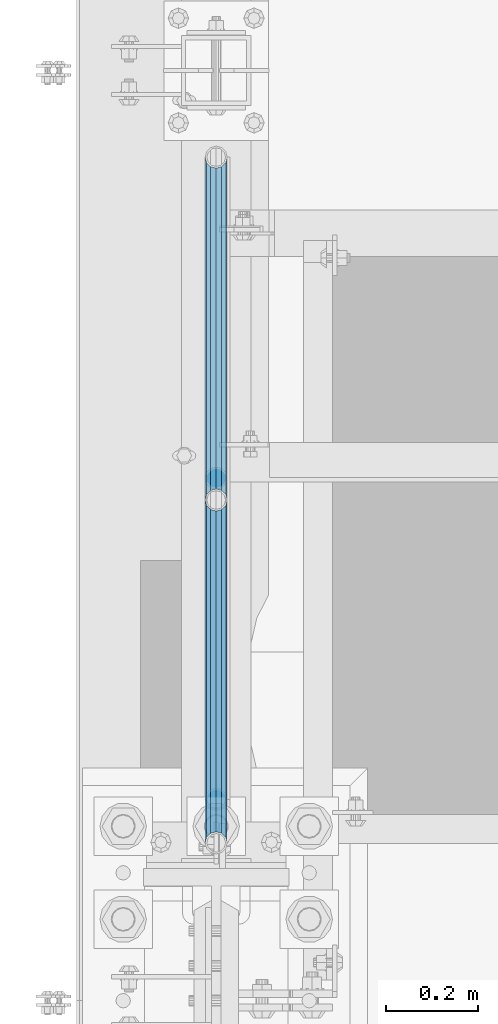
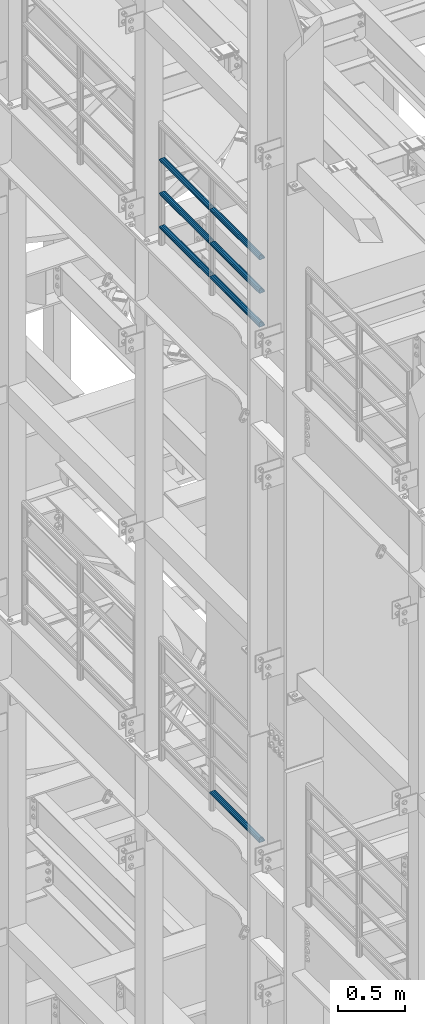
# One storey, part 1244 of 1876: 7 beams, 2 elements without a shape of their own.
"""IFC2X3 building model written with IfcOpenShell, lengths in millimetres."""

import ifcopenshell
import ifcopenshell.guid

model = None  # the IFC model being written
_history = None  # IfcOwnerHistory: only IFC2X3 demands one
_inside = {}  # id of a spatial element -> (the spatial element, [elements in it])
_under = {}  # id of a project, library or spatial element -> (it, [spatial elements below it])
_declared = {}  # id of a project -> (the project, [libraries it declares])
_typed = {}  # id of a type object -> (the type object, [elements of that type])
_made_of = {}  # id of a material, layer set ... -> (it, [elements and type objects made of it])


def new_model(schema):
    """Start an empty IFC model of exactly this schema.

    Asked for "IFC4X3", IfcOpenShell would pick the latest addendum, in which some entities
    have other attributes; the version numbers below select the first issue.
    IFC2X3 requires an IfcOwnerHistory on every rooted entity: one is made here for all.
    """
    global model, _history
    if schema == "IFC4X3":
        model = ifcopenshell.file(schema_version=(4, 3, 0, 0))
    else:
        model = ifcopenshell.file(schema=schema)
    _inside.clear()
    _under.clear()
    _declared.clear()
    _typed.clear()
    _made_of.clear()
    _history = None
    if model.schema == "IFC2X3":
        org = make("IfcOrganization", Name="unknown")
        user = make(
            "IfcPersonAndOrganization",
            ThePerson=make("IfcPerson", FamilyName="unknown"),
            TheOrganization=org,
        )
        app = make(
            "IfcApplication",
            ApplicationDeveloper=org,
            Version="unknown",
            ApplicationFullName="unknown",
            ApplicationIdentifier="unknown",
        )
        _history = make(
            "IfcOwnerHistory",
            OwningUser=user,
            OwningApplication=app,
            ChangeAction="ADDED",
            CreationDate=0,
        )
    return model


def make(cls, **values):
    """One entity of the class cls with the attributes given. An attribute that is None is left unset."""
    return model.create_entity(
        cls, **{name: value for name, value in values.items() if value is not None}
    )


def rooted(cls, **values):
    """An entity with a GlobalId (a new one), such as an element, a storey or a relation."""
    return make(cls, GlobalId=ifcopenshell.guid.new(), OwnerHistory=_history, **values)


def si_unit(unit_type, name, prefix=None):
    """IfcSIUnit, for example si_unit("LENGTHUNIT", "METRE", prefix="MILLI")."""
    return make("IfcSIUnit", UnitType=unit_type, Prefix=prefix, Name=name)


def assignment(units):
    """IfcUnitAssignment: the units of a project."""
    return None if units is None else make("IfcUnitAssignment", Units=units)


def point(xyz):
    """IfcCartesianPoint."""
    return None if xyz is None else make("IfcCartesianPoint", Coordinates=xyz)


def direction(xyz):
    """IfcDirection."""
    return None if xyz is None else make("IfcDirection", DirectionRatios=xyz)


def frame(location, z_axis=None, x_axis=None):
    """IfcAxis2Placement3D, a coordinate frame: its origin and axes. An axis left out is left unset."""
    return make(
        "IfcAxis2Placement3D",
        Location=point(location),
        Axis=direction(z_axis),
        RefDirection=direction(x_axis),
    )


def origin_with_axes():
    """The frame at (0, 0, 0) with the z axis (0, 0, 1) and the x axis (1, 0, 0) written out."""
    return frame((0.0, 0.0, 0.0), z_axis=(0.0, 0.0, 1.0), x_axis=(1.0, 0.0, 0.0))


def place(relative_to, where):
    """IfcLocalPlacement: puts the frame where relative to a parent placement (None: the world)."""
    return make(
        "IfcLocalPlacement", PlacementRelTo=relative_to, RelativePlacement=where
    )


def context(
    kind, dimensions, precision=None, world=None, true_north=None, identifier=None
):
    """IfcGeometricRepresentationContext, for example the 3D "Model" context."""
    return make(
        "IfcGeometricRepresentationContext",
        ContextIdentifier=identifier,
        ContextType=kind,
        CoordinateSpaceDimension=dimensions,
        Precision=precision,
        WorldCoordinateSystem=world,
        TrueNorth=true_north,
    )


def subcontext(parent, identifier, kind, view, scale=None):
    """IfcGeometricRepresentationSubContext, for example "Body" below "Model"."""
    return make(
        "IfcGeometricRepresentationSubContext",
        ContextIdentifier=identifier,
        ContextType=kind,
        ParentContext=parent,
        TargetScale=scale,
        TargetView=view,
    )


def project(units=None, contexts=None):
    """IfcProject with its units and contexts."""
    return rooted(
        "IfcProject",
        Name="project",
        RepresentationContexts=contexts,
        UnitsInContext=assignment(units),
    )


def spatial(cls, under=None, at=None, **own):
    """A site, building, storey or space (cls), placed at a placement, below another one or the project."""
    s = rooted(cls, ObjectPlacement=at, **own)
    if under is not None:
        _under.setdefault(under.id(), (under, []))[1].append(s)
    return s


def faces_of(points, faces, orient=None, outer=None):
    """IfcFace entities. A face is a list of loops; a loop is a list of indices into points, from 0.

    orient and outer hold one flag for each loop. By default every Orientation is true, the
    first loop of a face is its IfcFaceOuterBound and the others are IfcFaceBound.
    """
    made = []
    for i, loops in enumerate(faces):
        bounds = []
        for j, loop in enumerate(loops):
            is_outer = j == 0 if outer is None else outer[i][j]
            bounds.append(
                make(
                    "IfcFaceOuterBound" if is_outer else "IfcFaceBound",
                    Bound=make("IfcPolyLoop", Polygon=[points[k] for k in loop]),
                    Orientation=True if orient is None else orient[i][j],
                )
            )
        made.append(make("IfcFace", Bounds=bounds))
    return made


def faceted_brep(points, faces, orient=None, outer=None, voids=None):
    """IfcFacetedBrep: a solid bounded by flat faces; with voids (closed shells), ...WithVoids."""
    shared = [point(p) for p in points]
    hull = make("IfcClosedShell", CfsFaces=faces_of(shared, faces, orient, outer))
    if voids is None:
        return make("IfcFacetedBrep", Outer=hull)
    return make(
        "IfcFacetedBrepWithVoids",
        Outer=hull,
        Voids=[
            make(cls, CfsFaces=faces_of(shared, fs, o, b)) for cls, fs, o, b in voids
        ],
    )


def shape(context_of_items, identifier, shape_type, items):
    """IfcShapeRepresentation: the items that make up one representation, for example the "Body"."""
    return make(
        "IfcShapeRepresentation",
        ContextOfItems=context_of_items,
        RepresentationIdentifier=identifier,
        RepresentationType=shape_type,
        Items=items,
    )


def material(Name=None, Category=None):
    """IfcMaterial."""
    return make("IfcMaterial", Name=Name, Category=Category)


def made_of(thing, what):
    """Note that an element or type object is made of a material, layer set ...; save() writes the relation."""
    if what is not None:
        _made_of.setdefault(what.id(), (what, []))[1].append(thing)
    return thing


def type_object(cls, material=None, **own):
    """A type object (cls), such as IfcWallType, which elements share."""
    return made_of(rooted(cls, **own), material)


def element(
    cls,
    number,
    at=None,
    inside=None,
    cuts=None,
    type_object=None,
    material=None,
    context=None,
    identifier="Body",
    shape_type=None,
    held_by="IfcProductDefinitionShape",
    body=None,
    shapes=None,
    **own,
):
    """One element of the class cls, such as IfcWall. Its Tag is "e" and its number.

    at: its placement. inside: the storey or other place that contains it. cuts: it is an
    opening in that element (IfcRelVoidsElement). A single representation is given by context,
    identifier, shape_type and body (its items); several are given by shapes. held_by: the class
    of the entity that holds the representations. save() writes the other relations.
    """
    e = rooted(cls, Tag="e%d" % number, ObjectPlacement=at, **own)
    if body is not None:
        shapes = [shape(context, identifier, shape_type, body)]
    if shapes is not None:
        e.Representation = make(held_by, Representations=shapes)
    if inside is not None:
        _inside.setdefault(inside.id(), (inside, []))[1].append(e)
    if cuts is not None:
        rooted(
            "IfcRelVoidsElement", RelatingBuildingElement=cuts, RelatedOpeningElement=e
        )
    if type_object is not None:
        _typed.setdefault(type_object.id(), (type_object, []))[1].append(e)
    return made_of(e, material)


def aggregate(whole, parts):
    """IfcRelAggregates: a whole, such as a stair, and the parts it consists of."""
    return rooted("IfcRelAggregates", RelatingObject=whole, RelatedObjects=parts)


def save(model, path):
    """Write the relations noted so far, then the file.

    IfcRelAggregates (storeys below a building ...), IfcRelContainedInSpatialStructure (elements
    in a storey), IfcRelDefinesByType, IfcRelAssociatesMaterial and IfcRelDeclares: one each for
    every whole, place, type object, material and project.
    """
    for whole, parts in _under.values():
        aggregate(whole, parts)
    for where, things in _inside.values():
        rooted(
            "IfcRelContainedInSpatialStructure",
            RelatedElements=things,
            RelatingStructure=where,
        )
    for kind, things in _typed.values():
        rooted("IfcRelDefinesByType", RelatedObjects=things, RelatingType=kind)
    for what, things in _made_of.values():
        rooted("IfcRelAssociatesMaterial", RelatedObjects=things, RelatingMaterial=what)
    for by, libraries in _declared.values():
        rooted("IfcRelDeclares", RelatingContext=by, RelatedDefinitions=libraries)
    model.write(path)


model = new_model("IFC2X3")

# Units and contexts
model_context = context("Model", 3, precision=1e-05, world=origin_with_axes())
body_context = subcontext(model_context, "Body", "Model", "MODEL_VIEW")
ifc_project = project(units=[si_unit("LENGTHUNIT", "METRE", prefix="MILLI"), si_unit("AREAUNIT", "SQUARE_METRE"), si_unit("VOLUMEUNIT", "CUBIC_METRE"), si_unit("MASSUNIT", "GRAM", prefix="KILO"), si_unit("TIMEUNIT", "SECOND"), si_unit("PLANEANGLEUNIT", "RADIAN"), si_unit("SOLIDANGLEUNIT", "STERADIAN"), si_unit("THERMODYNAMICTEMPERATUREUNIT", "DEGREE_CELSIUS"), si_unit("LUMINOUSINTENSITYUNIT", "LUMEN")], contexts=[model_context])

# Site, building, storey
site_placement = place(None, origin_with_axes())
site = spatial("IfcSite", under=ifc_project, at=site_placement, CompositionType="ELEMENT")
building_placement = place(site_placement, origin_with_axes())
building = spatial("IfcBuilding", under=site, at=building_placement, Name="Undefined", CompositionType="ELEMENT")
storey_placement = place(building_placement, origin_with_axes())
storey = spatial("IfcBuildingStorey", under=building, at=storey_placement, Name="Undefined", CompositionType="ELEMENT", Elevation=0.0)

# Assembly, beams
assembly_1_placement = place(storey_placement, origin_with_axes())
assembly_1 = element("IfcElementAssembly", 1, at=assembly_1_placement, inside=storey, Name="RAIL", AssemblyPlace="NOTDEFINED", PredefinedType="RIGID_FRAME")
ifc_material = material()
beam_type = type_object("IfcBeamType", Name="PIPE1-1/2SCH40", PredefinedType="NOTDEFINED")
beam_1_placement = place(assembly_1_placement, frame((-1.81898940354586e-12, 2617.7875, 18145.125), z_axis=(0.0, 0.0, 1.0), x_axis=(0.0, -1.0, 0.0)))
beam_1 = element("IfcBeam", 2, at=beam_1_placement, type_object=beam_type, material=ifc_material, Name="RAIL", ObjectType="PIPE1-1/2SCH40", context=body_context, shape_type="Brep", body=[
    faceted_brep([(728.085307006683, -12.0649999999996, 20.8971929933177), (728.085307006683, -12.0649999999996, 15.8661214311796), (727.591878568821, -10.2235000000001, 17.7076214311819), (724.852500000002, 0.0, 20.4470000000001), (724.852500000002, 0.0, 24.130000000001), (727.591878568821, 10.2235000000001, 17.7076214311819), (728.085307006683, 12.0649999999996, 15.8661214311796), (728.085307006683, 12.0649999999996, 20.8971929933177), (748.982500000002, 24.1300000000001, 0.0), (736.917500000002, 20.8971929933186, 12.0649999999987), (736.917500000002, 20.8971929933186, -12.0649999999987), (733.727928437864, 17.7076214311801, 10.2235000000001), (736.467307006683, 20.4470000000001, 0.0), (733.727928437864, 17.7076214311801, -10.2235000000001), (728.085307006683, 12.0649999999996, -15.8661214311796), (728.085307006683, 12.0649999999996, -20.8971929933177), (727.591878568821, 10.2235000000001, -17.7076214311819), (724.852500000002, 0.0, -20.4470000000001), (724.852500000002, 0.0, -24.130000000001), (728.085307006683, -12.0649999999996, -15.8661214311796), (728.085307006683, -12.0649999999996, -20.8971929933177), (727.591878568821, -10.2235000000001, -17.7076214311819), (748.982500000002, -24.1300000000001, 0.0), (736.917500000002, -20.8971929933186, -12.0649999999987), (736.917500000002, -20.8971929933186, 12.0649999999987), (733.727928437864, -17.7076214311801, -10.2235000000001), (736.467307006683, -20.4470000000001, 0.0), (733.727928437864, -17.7076214311801, 10.2235000000001), (12.0650000000064, -20.8971929933177, -12.0649999999987), (20.8971929933249, -12.0650000000005, -20.8971929933177), (0.0, 24.1299999999992, 0.0), (12.0650000000064, 20.8971929933177, -12.0649999999987), (12.0650000000064, 20.8971929933177, 12.0649999999987), (20.8971929933249, 12.0650000000005, 20.8971929933177), (24.1300000000064, 0.0, 24.130000000001), (20.8971929933249, 12.0650000000005, -20.8971929933177), (24.1300000000063, 0.0, -24.130000000001), (24.1300000000063, 0.0, -20.4470000000001), (20.8971929933249, -12.0650000000005, -15.8661214311796), (21.3906214311868, -10.2235000000001, -17.7076214311819), (21.3906214311868, 10.2235000000001, -17.7076214311819), (20.8971929933249, 12.0650000000005, -15.8661214311796), (15.2545715621445, 17.7076214311801, -10.2235000000001), (12.5151929933249, 20.4470000000001, 0.0), (15.2545715621445, 17.7076214311801, 10.2235000000001), (20.8971929933249, 12.0650000000005, 15.8661214311796), (21.3906214311868, 10.2235000000001, 17.7076214311819), (24.1300000000064, 0.0, 20.4470000000001), (21.3906214311868, -10.2235000000001, 17.7076214311819), (20.8971929933249, -12.0650000000005, 15.8661214311796), (20.8971929933249, -12.0650000000005, 20.8971929933177), (12.0650000000064, -20.8971929933177, 12.0649999999987), (0.0, -24.1299999999992, 0.0), (15.2545715621445, -17.7076214311801, 10.2235000000001), (12.5151929933249, -20.4470000000001, 0.0), (15.2545715621445, -17.7076214311801, -10.2235000000001)], [[[0, 1, 2, 3, 4]], [[4, 3, 5, 6, 7]], [[8, 9, 10]], [[7, 6, 11, 12, 13, 14, 15, 10, 9]], [[16, 17, 18, 15, 14]], [[19, 20, 18, 17, 21]], [[22, 23, 24]], [[24, 23, 20, 19, 25, 26, 27, 1, 0]], [[28, 29, 20, 23]], [[30, 31, 32]], [[33, 34, 4, 7]], [[32, 33, 7, 9]], [[30, 32, 9, 8]], [[31, 30, 8, 10]], [[35, 31, 10, 15]], [[36, 35, 15, 18]], [[29, 36, 18, 20]], [[37, 36, 29, 38, 39]], [[40, 41, 35, 36, 37]], [[32, 31, 35, 41, 42, 43, 44, 45, 33]], [[33, 45, 46, 47, 34]], [[34, 47, 48, 49, 50]], [[34, 50, 0, 4]], [[50, 51, 24, 0]], [[51, 52, 22, 24]], [[52, 28, 23, 22]], [[51, 28, 52]], [[50, 49, 53, 54, 55, 38, 29, 28, 51]], [[55, 54, 26, 25]], [[21, 39, 38, 55, 25, 19]], [[37, 39, 21, 17]], [[40, 37, 17, 16]], [[42, 41, 40, 16, 14, 13]], [[43, 42, 13, 12]], [[44, 43, 12, 11]], [[5, 46, 45, 44, 11, 6]], [[47, 46, 5, 3]], [[48, 47, 3, 2]], [[53, 49, 48, 2, 1, 27]], [[54, 53, 27, 26]]]),
])
beam_2_placement = place(assembly_1_placement, frame((-1.81898940354586e-12, 3366.77, 18145.125), z_axis=(0.0, 0.0, 1.0), x_axis=(0.0, -1.0, 0.0)))
beam_2 = element("IfcBeam", 3, at=beam_2_placement, type_object=beam_type, material=ifc_material, Name="RAIL", ObjectType="PIPE1-1/2SCH40", context=body_context, shape_type="Brep", body=[
    faceted_brep([(728.085307006683, -12.0649999999996, 20.8971929933177), (728.085307006683, -12.0649999999996, 15.8661214311796), (727.591878568821, -10.2235000000001, 17.7076214311819), (724.852500000002, 0.0, 20.4470000000001), (724.852500000002, 0.0, 24.130000000001), (727.591878568821, 10.2235000000001, 17.7076214311819), (728.085307006683, 12.0649999999996, 15.8661214311796), (728.085307006683, 12.0649999999996, 20.8971929933177), (748.982500000002, 24.1300000000001, 0.0), (736.917500000002, 20.8971929933186, 12.0649999999987), (736.917500000002, 20.8971929933186, -12.0649999999987), (733.727928437864, 17.7076214311801, 10.2235000000001), (736.467307006683, 20.4470000000001, 0.0), (733.727928437864, 17.7076214311801, -10.2235000000001), (728.085307006683, 12.0649999999996, -15.8661214311796), (728.085307006683, 12.0649999999996, -20.8971929933177), (727.591878568821, 10.2235000000001, -17.7076214311819), (724.852500000002, 0.0, -20.4470000000001), (724.852500000002, 0.0, -24.130000000001), (728.085307006683, -12.0649999999996, -15.8661214311796), (728.085307006683, -12.0649999999996, -20.8971929933177), (727.591878568821, -10.2235000000001, -17.7076214311819), (748.982500000002, -24.1300000000001, 0.0), (736.917500000002, -20.8971929933186, -12.0649999999987), (736.917500000002, -20.8971929933186, 12.0649999999987), (733.727928437864, -17.7076214311801, -10.2235000000001), (736.467307006683, -20.4470000000001, 0.0), (733.727928437864, -17.7076214311801, 10.2235000000001), (12.0650000000064, -20.8971929933177, -12.0649999999987), (20.8971929933249, -12.0650000000005, -20.8971929933177), (0.0, 24.1299999999992, 0.0), (12.0650000000064, 20.8971929933177, -12.0649999999987), (12.0650000000064, 20.8971929933177, 12.0649999999987), (20.8971929933249, 12.0650000000005, 20.8971929933177), (24.1300000000064, 0.0, 24.130000000001), (20.8971929933249, 12.0650000000005, -20.8971929933177), (24.1300000000063, 0.0, -24.130000000001), (24.1300000000063, 0.0, -20.4470000000001), (20.8971929933249, -12.0650000000005, -15.8661214311796), (21.3906214311868, -10.2235000000001, -17.7076214311819), (21.3906214311868, 10.2235000000001, -17.7076214311819), (20.8971929933249, 12.0650000000005, -15.8661214311796), (15.2545715621445, 17.7076214311801, -10.2235000000001), (12.5151929933249, 20.4470000000001, 0.0), (15.2545715621445, 17.7076214311801, 10.2235000000001), (20.8971929933249, 12.0650000000005, 15.8661214311796), (21.3906214311868, 10.2235000000001, 17.7076214311819), (24.1300000000064, 0.0, 20.4470000000001), (21.3906214311868, -10.2235000000001, 17.7076214311819), (20.8971929933249, -12.0650000000005, 15.8661214311796), (20.8971929933249, -12.0650000000005, 20.8971929933177), (12.0650000000064, -20.8971929933177, 12.0649999999987), (0.0, -24.1299999999992, 0.0), (15.2545715621445, -17.7076214311801, 10.2235000000001), (12.5151929933249, -20.4470000000001, 0.0), (15.2545715621445, -17.7076214311801, -10.2235000000001)], [[[0, 1, 2, 3, 4]], [[4, 3, 5, 6, 7]], [[8, 9, 10]], [[7, 6, 11, 12, 13, 14, 15, 10, 9]], [[16, 17, 18, 15, 14]], [[19, 20, 18, 17, 21]], [[22, 23, 24]], [[24, 23, 20, 19, 25, 26, 27, 1, 0]], [[28, 29, 20, 23]], [[30, 31, 32]], [[33, 34, 4, 7]], [[32, 33, 7, 9]], [[30, 32, 9, 8]], [[31, 30, 8, 10]], [[35, 31, 10, 15]], [[36, 35, 15, 18]], [[29, 36, 18, 20]], [[37, 36, 29, 38, 39]], [[40, 41, 35, 36, 37]], [[32, 31, 35, 41, 42, 43, 44, 45, 33]], [[33, 45, 46, 47, 34]], [[34, 47, 48, 49, 50]], [[34, 50, 0, 4]], [[50, 51, 24, 0]], [[51, 52, 22, 24]], [[52, 28, 23, 22]], [[51, 28, 52]], [[50, 49, 53, 54, 55, 38, 29, 28, 51]], [[55, 54, 26, 25]], [[21, 39, 38, 55, 25, 19]], [[37, 39, 21, 17]], [[40, 37, 17, 16]], [[42, 41, 40, 16, 14, 13]], [[43, 42, 13, 12]], [[44, 43, 12, 11]], [[5, 46, 45, 44, 11, 6]], [[47, 46, 5, 3]], [[48, 47, 3, 2]], [[53, 49, 48, 2, 1, 27]], [[54, 53, 27, 26]]]),
])
beam_3_placement = place(assembly_1_placement, frame((-1.81898940354586e-12, 1868.805, 18449.925), z_axis=(0.0, 0.0, -1.0), x_axis=(0.0, 1.0, 0.0)))
beam_3 = element("IfcBeam", 4, at=beam_3_placement, type_object=beam_type, material=ifc_material, Name="RAIL", ObjectType="PIPE1-1/2SCH40", context=body_context, shape_type="Brep", body=[
    faceted_brep([(0.0, 24.1299999999992, 0.0), (12.0650000000064, 20.8971929933177, -12.0649999999987), (12.0650000000064, 20.8971929933177, 12.0649999999987), (12.0650000000064, -20.8971929933177, 12.0649999999987), (12.0650000000064, -20.8971929933177, -12.0649999999987), (0.0, -24.1299999999992, 0.0), (20.8971929933249, -12.0650000000005, 20.8971929933177), (20.8971929933249, -12.0650000000005, 15.8661214311796), (15.2545715621445, -17.7076214311801, 10.2235000000001), (12.5151929933249, -20.4470000000001, 0.0), (15.2545715621445, -17.7076214311801, -10.2235000000001), (20.8971929933249, -12.0650000000005, -15.8661214311796), (20.8971929933249, -12.0650000000005, -20.8971929933177), (24.1300000000063, 0.0, -20.4470000000001), (24.1300000000063, 0.0, -24.130000000001), (21.3906214311868, -10.2235000000001, -17.7076214311819), (21.3906214311868, 10.2235000000001, -17.7076214311819), (20.8971929933249, 12.0650000000005, -15.8661214311796), (20.8971929933249, 12.0650000000005, -20.8971929933177), (15.2545715621445, 17.7076214311801, -10.2235000000001), (12.5151929933249, 20.4470000000001, 0.0), (15.2545715621445, 17.7076214311801, 10.2235000000001), (20.8971929933249, 12.0650000000005, 15.8661214311796), (20.8971929933249, 12.0650000000005, 20.8971929933177), (21.3906214311868, 10.2235000000001, 17.7076214311819), (24.1300000000064, 0.0, 20.4470000000001), (24.1300000000064, 0.0, 24.130000000001), (21.3906214311868, -10.2235000000001, 17.7076214311819), (748.982500000002, 24.1300000000001, 0.0), (736.917500000002, 20.8971929933186, -12.0649999999987), (728.085307006683, 12.0649999999996, -20.8971929933177), (748.982500000002, -24.1300000000001, 0.0), (736.917500000002, -20.8971929933186, -12.0649999999987), (736.917500000002, -20.8971929933186, 12.0649999999987), (728.085307006683, -12.0649999999996, 20.8971929933177), (728.085307006683, -12.0649999999996, -20.8971929933177), (724.852500000002, 0.0, -24.130000000001), (727.591878568821, 10.2235000000001, -17.7076214311819), (724.852500000002, 0.0, -20.4470000000001), (728.085307006683, 12.0649999999996, -15.8661214311796), (728.085307006683, -12.0649999999996, -15.8661214311796), (727.591878568821, -10.2235000000001, -17.7076214311819), (733.727928437864, -17.7076214311801, -10.2235000000001), (736.467307006683, -20.4470000000001, 0.0), (733.727928437864, -17.7076214311801, 10.2235000000001), (728.085307006683, -12.0649999999996, 15.8661214311796), (727.591878568821, -10.2235000000001, 17.7076214311819), (724.852500000002, 0.0, 20.4470000000001), (724.852500000002, 0.0, 24.130000000001), (728.085307006683, 12.0649999999996, 20.8971929933177), (736.917500000002, 20.8971929933186, 12.0649999999987), (728.085307006683, 12.0649999999996, 15.8661214311796), (733.727928437864, 17.7076214311801, 10.2235000000001), (736.467307006683, 20.4470000000001, 0.0), (733.727928437864, 17.7076214311801, -10.2235000000001), (727.591878568821, 10.2235000000001, 17.7076214311819)], [[[0, 1, 2]], [[3, 4, 5]], [[6, 7, 8, 9, 10, 11, 12, 4, 3]], [[13, 14, 12, 11, 15]], [[16, 17, 18, 14, 13]], [[2, 1, 18, 17, 19, 20, 21, 22, 23]], [[23, 22, 24, 25, 26]], [[26, 25, 27, 7, 6]], [[1, 0, 28, 29]], [[18, 1, 29, 30]], [[31, 32, 33]], [[6, 3, 33, 34]], [[3, 5, 31, 33]], [[5, 4, 32, 31]], [[4, 12, 35, 32]], [[12, 14, 36, 35]], [[14, 18, 30, 36]], [[37, 38, 36, 30, 39]], [[40, 35, 36, 38, 41]], [[33, 32, 35, 40, 42, 43, 44, 45, 34]], [[34, 45, 46, 47, 48]], [[26, 6, 34, 48]], [[2, 23, 49, 50]], [[23, 26, 48, 49]], [[0, 2, 50, 28]], [[28, 50, 29]], [[49, 51, 52, 53, 54, 39, 30, 29, 50]], [[48, 47, 55, 51, 49]], [[25, 24, 55, 47]], [[55, 24, 22, 21, 52, 51]], [[21, 20, 53, 52]], [[20, 19, 54, 53]], [[19, 17, 16, 37, 39, 54]], [[16, 13, 38, 37]], [[13, 15, 41, 38]], [[41, 15, 11, 10, 42, 40]], [[10, 9, 43, 42]], [[9, 8, 44, 43]], [[8, 7, 27, 46, 45, 44]], [[27, 25, 47, 46]]]),
])
beam_4_placement = place(assembly_1_placement, frame((-1.81898940354586e-12, 2617.7875, 18449.925), z_axis=(0.0, 0.0, -1.0), x_axis=(0.0, 1.0, 0.0)))
beam_4 = element("IfcBeam", 5, at=beam_4_placement, type_object=beam_type, material=ifc_material, Name="RAIL", ObjectType="PIPE1-1/2SCH40", context=body_context, shape_type="Brep", body=[
    faceted_brep([(0.0, 24.1299999999992, 0.0), (12.0650000000064, 20.8971929933177, -12.0649999999987), (12.0650000000064, 20.8971929933177, 12.0649999999987), (12.0650000000064, -20.8971929933177, 12.0649999999987), (12.0650000000064, -20.8971929933177, -12.0649999999987), (0.0, -24.1299999999992, 0.0), (20.8971929933249, -12.0650000000005, 20.8971929933177), (20.8971929933249, -12.0650000000005, 15.8661214311796), (15.2545715621445, -17.7076214311801, 10.2235000000001), (12.5151929933249, -20.4470000000001, 0.0), (15.2545715621445, -17.7076214311801, -10.2235000000001), (20.8971929933249, -12.0650000000005, -15.8661214311796), (20.8971929933249, -12.0650000000005, -20.8971929933177), (24.1300000000063, 0.0, -20.4470000000001), (24.1300000000063, 0.0, -24.130000000001), (21.3906214311868, -10.2235000000001, -17.7076214311819), (21.3906214311868, 10.2235000000001, -17.7076214311819), (20.8971929933249, 12.0650000000005, -15.8661214311796), (20.8971929933249, 12.0650000000005, -20.8971929933177), (15.2545715621445, 17.7076214311801, -10.2235000000001), (12.5151929933249, 20.4470000000001, 0.0), (15.2545715621445, 17.7076214311801, 10.2235000000001), (20.8971929933249, 12.0650000000005, 15.8661214311796), (20.8971929933249, 12.0650000000005, 20.8971929933177), (21.3906214311868, 10.2235000000001, 17.7076214311819), (24.1300000000064, 0.0, 20.4470000000001), (24.1300000000064, 0.0, 24.130000000001), (21.3906214311868, -10.2235000000001, 17.7076214311819), (748.982500000002, 24.1300000000001, 0.0), (736.917500000002, 20.8971929933186, -12.0649999999987), (728.085307006683, 12.0649999999996, -20.8971929933177), (748.982500000002, -24.1300000000001, 0.0), (736.917500000002, -20.8971929933186, -12.0649999999987), (736.917500000002, -20.8971929933186, 12.0649999999987), (728.085307006683, -12.0649999999996, 20.8971929933177), (728.085307006683, -12.0649999999996, -20.8971929933177), (724.852500000002, 0.0, -24.130000000001), (727.591878568821, 10.2235000000001, -17.7076214311819), (724.852500000002, 0.0, -20.4470000000001), (728.085307006683, 12.0649999999996, -15.8661214311796), (728.085307006683, -12.0649999999996, -15.8661214311796), (727.591878568821, -10.2235000000001, -17.7076214311819), (733.727928437864, -17.7076214311801, -10.2235000000001), (736.467307006683, -20.4470000000001, 0.0), (733.727928437864, -17.7076214311801, 10.2235000000001), (728.085307006683, -12.0649999999996, 15.8661214311796), (727.591878568821, -10.2235000000001, 17.7076214311819), (724.852500000002, 0.0, 20.4470000000001), (724.852500000002, 0.0, 24.130000000001), (728.085307006683, 12.0649999999996, 20.8971929933177), (736.917500000002, 20.8971929933186, 12.0649999999987), (728.085307006683, 12.0649999999996, 15.8661214311796), (733.727928437864, 17.7076214311801, 10.2235000000001), (736.467307006683, 20.4470000000001, 0.0), (733.727928437864, 17.7076214311801, -10.2235000000001), (727.591878568821, 10.2235000000001, 17.7076214311819)], [[[0, 1, 2]], [[3, 4, 5]], [[6, 7, 8, 9, 10, 11, 12, 4, 3]], [[13, 14, 12, 11, 15]], [[16, 17, 18, 14, 13]], [[2, 1, 18, 17, 19, 20, 21, 22, 23]], [[23, 22, 24, 25, 26]], [[26, 25, 27, 7, 6]], [[1, 0, 28, 29]], [[18, 1, 29, 30]], [[31, 32, 33]], [[6, 3, 33, 34]], [[3, 5, 31, 33]], [[5, 4, 32, 31]], [[4, 12, 35, 32]], [[12, 14, 36, 35]], [[14, 18, 30, 36]], [[37, 38, 36, 30, 39]], [[40, 35, 36, 38, 41]], [[33, 32, 35, 40, 42, 43, 44, 45, 34]], [[34, 45, 46, 47, 48]], [[26, 6, 34, 48]], [[2, 23, 49, 50]], [[23, 26, 48, 49]], [[0, 2, 50, 28]], [[28, 50, 29]], [[49, 51, 52, 53, 54, 39, 30, 29, 50]], [[48, 47, 55, 51, 49]], [[25, 24, 55, 47]], [[55, 24, 22, 21, 52, 51]], [[21, 20, 53, 52]], [[20, 19, 54, 53]], [[19, 17, 16, 37, 39, 54]], [[16, 13, 38, 37]], [[13, 15, 41, 38]], [[41, 15, 11, 10, 42, 40]], [[10, 9, 43, 42]], [[9, 8, 44, 43]], [[8, 7, 27, 46, 45, 44]], [[27, 25, 47, 46]]]),
])
beam_5_placement = place(assembly_1_placement, frame((-1.81898940354586e-12, 1868.805, 18754.725), z_axis=(0.0, 0.0, -1.0), x_axis=(0.0, 1.0, 0.0)))
beam_5 = element("IfcBeam", 6, at=beam_5_placement, type_object=beam_type, material=ifc_material, Name="RAIL", ObjectType="PIPE1-1/2SCH40", context=body_context, shape_type="Brep", body=[
    faceted_brep([(0.0, 24.1299999999992, 0.0), (12.0650000000064, 20.8971929933177, -12.0649999999987), (12.0650000000064, 20.8971929933177, 12.0649999999987), (12.0650000000064, -20.8971929933177, 12.0649999999987), (12.0650000000064, -20.8971929933177, -12.0649999999987), (0.0, -24.1299999999992, 0.0), (20.8971929933249, -12.0650000000005, 20.8971929933177), (20.8971929933249, -12.0650000000005, 15.8661214311796), (15.2545715621445, -17.7076214311801, 10.2235000000001), (12.5151929933249, -20.4470000000001, 0.0), (15.2545715621445, -17.7076214311801, -10.2235000000001), (20.8971929933249, -12.0650000000005, -15.8661214311796), (20.8971929933249, -12.0650000000005, -20.8971929933177), (24.1300000000063, 0.0, -20.4470000000001), (24.1300000000063, 0.0, -24.130000000001), (21.3906214311868, -10.2235000000001, -17.7076214311819), (21.3906214311868, 10.2235000000001, -17.7076214311819), (20.8971929933249, 12.0650000000005, -15.8661214311796), (20.8971929933249, 12.0650000000005, -20.8971929933177), (15.2545715621445, 17.7076214311801, -10.2235000000001), (12.5151929933249, 20.4470000000001, 0.0), (15.2545715621445, 17.7076214311801, 10.2235000000001), (20.8971929933249, 12.0650000000005, 15.8661214311796), (20.8971929933249, 12.0650000000005, 20.8971929933177), (21.3906214311868, 10.2235000000001, 17.7076214311819), (24.1300000000064, 0.0, 20.4470000000001), (24.1300000000064, 0.0, 24.130000000001), (21.3906214311868, -10.2235000000001, 17.7076214311819), (748.982500000002, 24.1300000000001, 0.0), (736.917500000002, 20.8971929933186, -12.0649999999987), (728.085307006683, 12.0649999999996, -20.8971929933177), (748.982500000002, -24.1300000000001, 0.0), (736.917500000002, -20.8971929933186, -12.0649999999987), (736.917500000002, -20.8971929933186, 12.0649999999987), (728.085307006683, -12.0649999999996, 20.8971929933177), (728.085307006683, -12.0649999999996, -20.8971929933177), (724.852500000002, 0.0, -24.130000000001), (727.591878568821, 10.2235000000001, -17.7076214311819), (724.852500000002, 0.0, -20.4470000000001), (728.085307006683, 12.0649999999996, -15.8661214311796), (728.085307006683, -12.0649999999996, -15.8661214311796), (727.591878568821, -10.2235000000001, -17.7076214311819), (733.727928437864, -17.7076214311801, -10.2235000000001), (736.467307006683, -20.4470000000001, 0.0), (733.727928437864, -17.7076214311801, 10.2235000000001), (728.085307006683, -12.0649999999996, 15.8661214311796), (727.591878568821, -10.2235000000001, 17.7076214311819), (724.852500000002, 0.0, 20.4470000000001), (724.852500000002, 0.0, 24.130000000001), (728.085307006683, 12.0649999999996, 20.8971929933177), (736.917500000002, 20.8971929933186, 12.0649999999987), (728.085307006683, 12.0649999999996, 15.8661214311796), (733.727928437864, 17.7076214311801, 10.2235000000001), (736.467307006683, 20.4470000000001, 0.0), (733.727928437864, 17.7076214311801, -10.2235000000001), (727.591878568821, 10.2235000000001, 17.7076214311819)], [[[0, 1, 2]], [[3, 4, 5]], [[6, 7, 8, 9, 10, 11, 12, 4, 3]], [[13, 14, 12, 11, 15]], [[16, 17, 18, 14, 13]], [[2, 1, 18, 17, 19, 20, 21, 22, 23]], [[23, 22, 24, 25, 26]], [[26, 25, 27, 7, 6]], [[1, 0, 28, 29]], [[18, 1, 29, 30]], [[31, 32, 33]], [[6, 3, 33, 34]], [[3, 5, 31, 33]], [[5, 4, 32, 31]], [[4, 12, 35, 32]], [[12, 14, 36, 35]], [[14, 18, 30, 36]], [[37, 38, 36, 30, 39]], [[40, 35, 36, 38, 41]], [[33, 32, 35, 40, 42, 43, 44, 45, 34]], [[34, 45, 46, 47, 48]], [[26, 6, 34, 48]], [[2, 23, 49, 50]], [[23, 26, 48, 49]], [[0, 2, 50, 28]], [[28, 50, 29]], [[49, 51, 52, 53, 54, 39, 30, 29, 50]], [[48, 47, 55, 51, 49]], [[25, 24, 55, 47]], [[55, 24, 22, 21, 52, 51]], [[21, 20, 53, 52]], [[20, 19, 54, 53]], [[19, 17, 16, 37, 39, 54]], [[16, 13, 38, 37]], [[13, 15, 41, 38]], [[41, 15, 11, 10, 42, 40]], [[10, 9, 43, 42]], [[9, 8, 44, 43]], [[8, 7, 27, 46, 45, 44]], [[27, 25, 47, 46]]]),
])
beam_6_placement = place(assembly_1_placement, frame((-1.81898940354586e-12, 2617.7875, 18754.725), z_axis=(0.0, 0.0, -1.0), x_axis=(0.0, 1.0, 0.0)))
beam_6 = element("IfcBeam", 7, at=beam_6_placement, type_object=beam_type, material=ifc_material, Name="RAIL", ObjectType="PIPE1-1/2SCH40", context=body_context, shape_type="Brep", body=[
    faceted_brep([(0.0, 24.1299999999992, 0.0), (12.0650000000064, 20.8971929933177, -12.0649999999987), (12.0650000000064, 20.8971929933177, 12.0649999999987), (12.0650000000064, -20.8971929933177, 12.0649999999987), (12.0650000000064, -20.8971929933177, -12.0649999999987), (0.0, -24.1299999999992, 0.0), (20.8971929933249, -12.0650000000005, 20.8971929933177), (20.8971929933249, -12.0650000000005, 15.8661214311796), (15.2545715621445, -17.7076214311801, 10.2235000000001), (12.5151929933249, -20.4470000000001, 0.0), (15.2545715621445, -17.7076214311801, -10.2235000000001), (20.8971929933249, -12.0650000000005, -15.8661214311796), (20.8971929933249, -12.0650000000005, -20.8971929933177), (24.1300000000063, 0.0, -20.4470000000001), (24.1300000000063, 0.0, -24.130000000001), (21.3906214311868, -10.2235000000001, -17.7076214311819), (21.3906214311868, 10.2235000000001, -17.7076214311819), (20.8971929933249, 12.0650000000005, -15.8661214311796), (20.8971929933249, 12.0650000000005, -20.8971929933177), (15.2545715621445, 17.7076214311801, -10.2235000000001), (12.5151929933249, 20.4470000000001, 0.0), (15.2545715621445, 17.7076214311801, 10.2235000000001), (20.8971929933249, 12.0650000000005, 15.8661214311796), (20.8971929933249, 12.0650000000005, 20.8971929933177), (21.3906214311868, 10.2235000000001, 17.7076214311819), (24.1300000000064, 0.0, 20.4470000000001), (24.1300000000064, 0.0, 24.130000000001), (21.3906214311868, -10.2235000000001, 17.7076214311819), (748.982500000002, 24.1300000000001, 0.0), (736.917500000002, 20.8971929933186, -12.0649999999987), (728.085307006683, 12.0649999999996, -20.8971929933177), (748.982500000002, -24.1300000000001, 0.0), (736.917500000002, -20.8971929933186, -12.0649999999987), (736.917500000002, -20.8971929933186, 12.0649999999987), (728.085307006683, -12.0649999999996, 20.8971929933177), (728.085307006683, -12.0649999999996, -20.8971929933177), (724.852500000002, 0.0, -24.130000000001), (727.591878568821, 10.2235000000001, -17.7076214311819), (724.852500000002, 0.0, -20.4470000000001), (728.085307006683, 12.0649999999996, -15.8661214311796), (728.085307006683, -12.0649999999996, -15.8661214311796), (727.591878568821, -10.2235000000001, -17.7076214311819), (733.727928437864, -17.7076214311801, -10.2235000000001), (736.467307006683, -20.4470000000001, 0.0), (733.727928437864, -17.7076214311801, 10.2235000000001), (728.085307006683, -12.0649999999996, 15.8661214311796), (727.591878568821, -10.2235000000001, 17.7076214311819), (724.852500000002, 0.0, 20.4470000000001), (724.852500000002, 0.0, 24.130000000001), (728.085307006683, 12.0649999999996, 20.8971929933177), (736.917500000002, 20.8971929933186, 12.0649999999987), (728.085307006683, 12.0649999999996, 15.8661214311796), (733.727928437864, 17.7076214311801, 10.2235000000001), (736.467307006683, 20.4470000000001, 0.0), (733.727928437864, 17.7076214311801, -10.2235000000001), (727.591878568821, 10.2235000000001, 17.7076214311819)], [[[0, 1, 2]], [[3, 4, 5]], [[6, 7, 8, 9, 10, 11, 12, 4, 3]], [[13, 14, 12, 11, 15]], [[16, 17, 18, 14, 13]], [[2, 1, 18, 17, 19, 20, 21, 22, 23]], [[23, 22, 24, 25, 26]], [[26, 25, 27, 7, 6]], [[1, 0, 28, 29]], [[18, 1, 29, 30]], [[31, 32, 33]], [[6, 3, 33, 34]], [[3, 5, 31, 33]], [[5, 4, 32, 31]], [[4, 12, 35, 32]], [[12, 14, 36, 35]], [[14, 18, 30, 36]], [[37, 38, 36, 30, 39]], [[40, 35, 36, 38, 41]], [[33, 32, 35, 40, 42, 43, 44, 45, 34]], [[34, 45, 46, 47, 48]], [[26, 6, 34, 48]], [[2, 23, 49, 50]], [[23, 26, 48, 49]], [[0, 2, 50, 28]], [[28, 50, 29]], [[49, 51, 52, 53, 54, 39, 30, 29, 50]], [[48, 47, 55, 51, 49]], [[25, 24, 55, 47]], [[55, 24, 22, 21, 52, 51]], [[21, 20, 53, 52]], [[20, 19, 54, 53]], [[19, 17, 16, 37, 39, 54]], [[16, 13, 38, 37]], [[13, 15, 41, 38]], [[41, 15, 11, 10, 42, 40]], [[10, 9, 43, 42]], [[9, 8, 44, 43]], [[8, 7, 27, 46, 45, 44]], [[27, 25, 47, 46]]]),
])
aggregate(assembly_1, [beam_1, beam_2, beam_3, beam_4, beam_5, beam_6])

# Assembly, beam
assembly_2_placement = place(storey_placement, origin_with_axes())
assembly_2 = element("IfcElementAssembly", 8, at=assembly_2_placement, inside=storey, Name="RAIL", AssemblyPlace="NOTDEFINED", PredefinedType="RIGID_FRAME")
beam_7_placement = place(assembly_2_placement, frame((-1.81898940354586e-12, 2617.7875, 13471.525), z_axis=(0.0, 0.0, 1.0), x_axis=(0.0, -1.0, 0.0)))
beam_7 = element("IfcBeam", 9, at=beam_7_placement, type_object=beam_type, material=ifc_material, Name="RAIL", ObjectType="PIPE1-1/2SCH40", context=body_context, shape_type="Brep", body=[
    faceted_brep([(728.085307006683, -12.0649999999996, 20.8971929933177), (728.085307006683, -12.0649999999996, 15.8661214311796), (727.591878568821, -10.2235000000001, 17.7076214311819), (724.852500000002, 0.0, 20.4470000000001), (724.852500000002, 0.0, 24.130000000001), (727.591878568821, 10.2235000000001, 17.7076214311819), (728.085307006683, 12.0649999999996, 15.8661214311796), (728.085307006683, 12.0649999999996, 20.8971929933177), (748.982500000002, 24.1300000000001, 0.0), (736.917500000002, 20.8971929933186, 12.0649999999987), (736.917500000002, 20.8971929933186, -12.0649999999987), (733.727928437864, 17.7076214311801, 10.2235000000001), (736.467307006683, 20.4470000000001, 0.0), (733.727928437864, 17.7076214311801, -10.2235000000001), (728.085307006683, 12.0649999999996, -15.8661214311796), (728.085307006683, 12.0649999999996, -20.8971929933177), (727.591878568821, 10.2235000000001, -17.7076214311819), (724.852500000002, 0.0, -20.4470000000001), (724.852500000002, 0.0, -24.130000000001), (728.085307006683, -12.0649999999996, -15.8661214311796), (728.085307006683, -12.0649999999996, -20.8971929933177), (727.591878568821, -10.2235000000001, -17.7076214311819), (748.982500000002, -24.1300000000001, 0.0), (736.917500000002, -20.8971929933186, -12.0649999999987), (736.917500000002, -20.8971929933186, 12.0649999999987), (733.727928437864, -17.7076214311801, -10.2235000000001), (736.467307006683, -20.4470000000001, 0.0), (733.727928437864, -17.7076214311801, 10.2235000000001), (12.0650000000064, -20.8971929933177, -12.0649999999987), (20.8971929933249, -12.0650000000005, -20.8971929933177), (0.0, 24.1299999999992, 0.0), (12.0650000000064, 20.8971929933177, -12.0649999999987), (12.0650000000064, 20.8971929933177, 12.0649999999987), (20.8971929933249, 12.0650000000005, 20.8971929933177), (24.1300000000064, 0.0, 24.130000000001), (20.8971929933249, 12.0650000000005, -20.8971929933177), (24.1300000000063, 0.0, -24.130000000001), (24.1300000000063, 0.0, -20.4470000000001), (20.8971929933249, -12.0650000000005, -15.8661214311796), (21.3906214311868, -10.2235000000001, -17.7076214311819), (21.3906214311868, 10.2235000000001, -17.7076214311819), (20.8971929933249, 12.0650000000005, -15.8661214311796), (15.2545715621445, 17.7076214311801, -10.2235000000001), (12.5151929933249, 20.4470000000001, 0.0), (15.2545715621445, 17.7076214311801, 10.2235000000001), (20.8971929933249, 12.0650000000005, 15.8661214311796), (21.3906214311868, 10.2235000000001, 17.7076214311819), (24.1300000000064, 0.0, 20.4470000000001), (21.3906214311868, -10.2235000000001, 17.7076214311819), (20.8971929933249, -12.0650000000005, 15.8661214311796), (20.8971929933249, -12.0650000000005, 20.8971929933177), (12.0650000000064, -20.8971929933177, 12.0649999999987), (0.0, -24.1299999999992, 0.0), (15.2545715621445, -17.7076214311801, 10.2235000000001), (12.5151929933249, -20.4470000000001, 0.0), (15.2545715621445, -17.7076214311801, -10.2235000000001)], [[[0, 1, 2, 3, 4]], [[4, 3, 5, 6, 7]], [[8, 9, 10]], [[7, 6, 11, 12, 13, 14, 15, 10, 9]], [[16, 17, 18, 15, 14]], [[19, 20, 18, 17, 21]], [[22, 23, 24]], [[24, 23, 20, 19, 25, 26, 27, 1, 0]], [[28, 29, 20, 23]], [[30, 31, 32]], [[33, 34, 4, 7]], [[32, 33, 7, 9]], [[30, 32, 9, 8]], [[31, 30, 8, 10]], [[35, 31, 10, 15]], [[36, 35, 15, 18]], [[29, 36, 18, 20]], [[37, 36, 29, 38, 39]], [[40, 41, 35, 36, 37]], [[32, 31, 35, 41, 42, 43, 44, 45, 33]], [[33, 45, 46, 47, 34]], [[34, 47, 48, 49, 50]], [[34, 50, 0, 4]], [[50, 51, 24, 0]], [[51, 52, 22, 24]], [[52, 28, 23, 22]], [[51, 28, 52]], [[50, 49, 53, 54, 55, 38, 29, 28, 51]], [[55, 54, 26, 25]], [[21, 39, 38, 55, 25, 19]], [[37, 39, 21, 17]], [[40, 37, 17, 16]], [[42, 41, 40, 16, 14, 13]], [[43, 42, 13, 12]], [[44, 43, 12, 11]], [[5, 46, 45, 44, 11, 6]], [[47, 46, 5, 3]], [[48, 47, 3, 2]], [[53, 49, 48, 2, 1, 27]], [[54, 53, 27, 26]]]),
])
aggregate(assembly_2, [beam_7])

save(model, "model.ifc")
